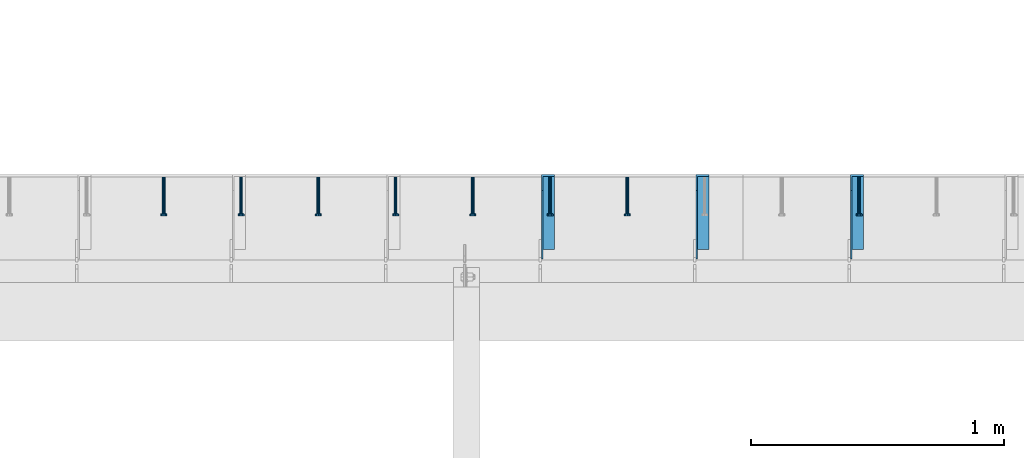
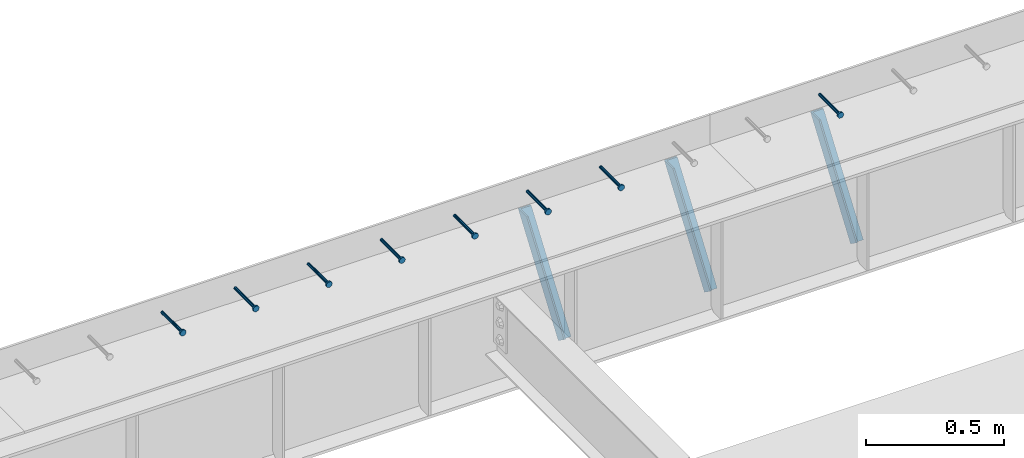
# One storey, part 1338 of 1763: 8 beams, 3 members, 9 elements without a shape of their own.
"""IFC2X3 building model written with IfcOpenShell, lengths in millimetres."""

from ifc_helpers import new_model, si_unit, frame, origin_with_axes, place, context, subcontext, project, spatial, faceted_brep, material, type_object, element, aggregate, save


model = new_model("IFC2X3")

# Units and contexts
model_context = context("Model", 3, precision=1e-05, world=origin_with_axes())
body_context = subcontext(model_context, "Body", "Model", "MODEL_VIEW")
ifc_project = project(units=[si_unit("LENGTHUNIT", "METRE", prefix="MILLI"), si_unit("AREAUNIT", "SQUARE_METRE"), si_unit("VOLUMEUNIT", "CUBIC_METRE"), si_unit("MASSUNIT", "GRAM", prefix="KILO"), si_unit("TIMEUNIT", "SECOND"), si_unit("PLANEANGLEUNIT", "RADIAN"), si_unit("SOLIDANGLEUNIT", "STERADIAN"), si_unit("THERMODYNAMICTEMPERATUREUNIT", "DEGREE_CELSIUS"), si_unit("LUMINOUSINTENSITYUNIT", "LUMEN")], contexts=[model_context])

# Site, building, storey
site_placement = place(None, origin_with_axes())
site = spatial("IfcSite", under=ifc_project, at=site_placement, CompositionType="ELEMENT")
building_placement = place(site_placement, origin_with_axes())
building = spatial("IfcBuilding", under=site, at=building_placement, Name="Undefined", CompositionType="ELEMENT")
storey_placement = place(building_placement, origin_with_axes())
storey = spatial("IfcBuildingStorey", under=building, at=storey_placement, Name="Undefined", CompositionType="ELEMENT", Elevation=0.0)

# Assembly, beam
assembly_1_placement = place(storey_placement, origin_with_axes())
assembly_1 = element("IfcElementAssembly", 1, at=assembly_1_placement, inside=storey, Name="HEADED STUD ANCHOR", AssemblyPlace="NOTDEFINED", PredefinedType="RIGID_FRAME")
ifc_material_1 = material(Name="STEEL/A108")
beam_type = type_object("IfcBeamType", PredefinedType="NOTDEFINED")
beam_1_placement = place(assembly_1_placement, frame((-78383.8372736983, 53984.5250183106, 5264.23140606069), z_axis=(0.0, 0.0, 1.0), x_axis=(0.0, -1.0, 0.0)))
beam_1 = element("IfcBeam", 2, at=beam_1_placement, type_object=beam_type, material=ifc_material_1, Name="HEADED STUD ANCHOR", context=body_context, shape_type="Brep", body=[
    faceted_brep([(0.0, -3.1800000667572, 5.5), (0.0, -5.5, 3.1800000667572), (141.732000000002, -5.5, 3.1800000667572), (141.732000000002, -3.1800000667572, 5.5), (0.0, -6.34999999999491, 1.45519152283669e-11), (141.732000000002, -6.34999990463257, 0.0), (0.0, -5.5, -3.1800000667572), (141.732000000002, -5.5, -3.1800000667572), (0.0, -3.1800000667572, -5.5), (141.732000000002, -3.1800000667572, -5.5), (0.0, 0.0, -6.34999990463257), (141.732000000002, 0.0, -6.34999990463257), (0.0, 3.1800000667572, -5.5), (141.732000000002, 3.1800000667572, -5.5), (0.0, 5.5, -3.1800000667572), (141.732000000002, 5.5, -3.1800000667572), (0.0, 6.34999999999491, -2.91038304567337e-11), (141.732000000002, 6.34999990463257, 0.0), (0.0, 5.5, 3.1800000667572), (141.732000000002, 5.5, 3.1800000667572), (0.0, 3.1800000667572, 5.5), (141.732000000002, 3.1800000667572, 5.5), (0.0, 0.0, 6.34999990463257), (141.732000000002, 0.0, 6.34999990463257), (144.780000000001, -10.9899997711182, 6.34999990463257), (144.780000000001, -6.34000015258789, 10.9899997711182), (144.780000000001, -12.6999998092651, 0.0), (144.780000000001, -10.9899997711182, -6.34999990463257), (144.780000000001, -6.34000015258789, -10.9899997711182), (144.780000000001, 0.0, -12.6899995803833), (144.780000000001, 6.34000015258789, -10.9899997711182), (144.780000000001, 10.9899997711182, -6.34999990463257), (144.780000000001, 12.6999998092651, 0.0), (144.780000000001, 10.9899997711182, 6.34999990463257), (144.780000000001, 6.34000015258789, 10.9899997711182), (144.780000000001, 0.0, 12.6899995803833), (152.400000000001, -10.9899997711182, 6.34999990463257), (152.400000000001, -6.34000015258789, 10.9899997711182), (152.400000000001, -12.6999998092651, 0.0), (152.400000000001, -10.9899997711182, -6.34999990463257), (152.400000000001, -6.34000015258789, -10.9899997711182), (152.400000000001, 0.0, -12.6899995803833), (152.400000000001, 6.34000015258789, -10.9899997711182), (152.400000000001, 10.9899997711182, -6.34999990463257), (152.400000000001, 12.6999998092651, 0.0), (152.400000000001, 10.9899997711182, 6.34999990463257), (152.400000000001, 6.34000015258789, 10.9899997711182), (152.400000000001, 0.0, 12.6899995803833)], [[[0, 1, 2, 3]], [[1, 4, 5, 2]], [[4, 6, 7, 5]], [[6, 8, 9, 7]], [[8, 10, 11, 9]], [[10, 12, 13, 11]], [[12, 14, 15, 13]], [[14, 16, 17, 15]], [[16, 18, 19, 17]], [[18, 20, 21, 19]], [[20, 22, 23, 21]], [[22, 0, 3, 23]], [[22, 20, 18, 16, 14, 12, 10, 8, 6, 4, 1, 0]], [[3, 2, 24, 25]], [[2, 5, 26, 24]], [[5, 7, 27, 26]], [[7, 9, 28, 27]], [[9, 11, 29, 28]], [[11, 13, 30, 29]], [[13, 15, 31, 30]], [[15, 17, 32, 31]], [[17, 19, 33, 32]], [[19, 21, 34, 33]], [[21, 23, 35, 34]], [[23, 3, 25, 35]], [[25, 24, 36, 37]], [[24, 26, 38, 36]], [[26, 27, 39, 38]], [[27, 28, 40, 39]], [[28, 29, 41, 40]], [[29, 30, 42, 41]], [[30, 31, 43, 42]], [[31, 32, 44, 43]], [[32, 33, 45, 44]], [[33, 34, 46, 45]], [[34, 35, 47, 46]], [[35, 25, 37, 47]], [[38, 39, 40, 41, 42, 43, 44, 45, 46, 47, 37, 36]]]),
])
aggregate(assembly_1, [beam_1])

assembly_2_placement = place(storey_placement, origin_with_axes())
assembly_2 = element("IfcElementAssembly", 3, at=assembly_2_placement, inside=storey, Name="HEADED STUD ANCHOR", AssemblyPlace="NOTDEFINED", PredefinedType="RIGID_FRAME")
beam_2_placement = place(assembly_2_placement, frame((-79298.2372736984, 53984.5250183106, 5264.23140606069), z_axis=(0.0, 0.0, 1.0), x_axis=(0.0, -1.0, 0.0)))
beam_2 = element("IfcBeam", 4, at=beam_2_placement, type_object=beam_type, material=ifc_material_1, Name="HEADED STUD ANCHOR", context=body_context, shape_type="Brep", body=[
    faceted_brep([(0.0, -3.1800000667572, 5.5), (0.0, -5.5, 3.1800000667572), (141.732000000002, -5.5, 3.1800000667572), (141.732000000002, -3.1800000667572, 5.5), (0.0, -6.34999999999491, 1.45519152283669e-11), (141.732000000002, -6.34999990463257, 0.0), (0.0, -5.5, -3.1800000667572), (141.732000000002, -5.5, -3.1800000667572), (0.0, -3.1800000667572, -5.5), (141.732000000002, -3.1800000667572, -5.5), (0.0, 0.0, -6.34999990463257), (141.732000000002, 0.0, -6.34999990463257), (0.0, 3.1800000667572, -5.5), (141.732000000002, 3.1800000667572, -5.5), (0.0, 5.5, -3.1800000667572), (141.732000000002, 5.5, -3.1800000667572), (0.0, 6.34999999999491, -2.91038304567337e-11), (141.732000000002, 6.34999990463257, 0.0), (0.0, 5.5, 3.1800000667572), (141.732000000002, 5.5, 3.1800000667572), (0.0, 3.1800000667572, 5.5), (141.732000000002, 3.1800000667572, 5.5), (0.0, 0.0, 6.34999990463257), (141.732000000002, 0.0, 6.34999990463257), (144.780000000001, -10.9899997711182, 6.34999990463257), (144.780000000001, -6.34000015258789, 10.9899997711182), (144.780000000001, -12.6999998092651, 0.0), (144.780000000001, -10.9899997711182, -6.34999990463257), (144.780000000001, -6.34000015258789, -10.9899997711182), (144.780000000001, 0.0, -12.6899995803833), (144.780000000001, 6.34000015258789, -10.9899997711182), (144.780000000001, 10.9899997711182, -6.34999990463257), (144.780000000001, 12.6999998092651, 0.0), (144.780000000001, 10.9899997711182, 6.34999990463257), (144.780000000001, 6.34000015258789, 10.9899997711182), (144.780000000001, 0.0, 12.6899995803833), (152.400000000001, -10.9899997711182, 6.34999990463257), (152.400000000001, -6.34000015258789, 10.9899997711182), (152.400000000001, -12.6999998092651, 0.0), (152.400000000001, -10.9899997711182, -6.34999990463257), (152.400000000001, -6.34000015258789, -10.9899997711182), (152.400000000001, 0.0, -12.6899995803833), (152.400000000001, 6.34000015258789, -10.9899997711182), (152.400000000001, 10.9899997711182, -6.34999990463257), (152.400000000001, 12.6999998092651, 0.0), (152.400000000001, 10.9899997711182, 6.34999990463257), (152.400000000001, 6.34000015258789, 10.9899997711182), (152.400000000001, 0.0, 12.6899995803833)], [[[0, 1, 2, 3]], [[1, 4, 5, 2]], [[4, 6, 7, 5]], [[6, 8, 9, 7]], [[8, 10, 11, 9]], [[10, 12, 13, 11]], [[12, 14, 15, 13]], [[14, 16, 17, 15]], [[16, 18, 19, 17]], [[18, 20, 21, 19]], [[20, 22, 23, 21]], [[22, 0, 3, 23]], [[22, 20, 18, 16, 14, 12, 10, 8, 6, 4, 1, 0]], [[3, 2, 24, 25]], [[2, 5, 26, 24]], [[5, 7, 27, 26]], [[7, 9, 28, 27]], [[9, 11, 29, 28]], [[11, 13, 30, 29]], [[13, 15, 31, 30]], [[15, 17, 32, 31]], [[17, 19, 33, 32]], [[19, 21, 34, 33]], [[21, 23, 35, 34]], [[23, 3, 25, 35]], [[25, 24, 36, 37]], [[24, 26, 38, 36]], [[26, 27, 39, 38]], [[27, 28, 40, 39]], [[28, 29, 41, 40]], [[29, 30, 42, 41]], [[30, 31, 43, 42]], [[31, 32, 44, 43]], [[32, 33, 45, 44]], [[33, 34, 46, 45]], [[34, 35, 47, 46]], [[35, 25, 37, 47]], [[38, 39, 40, 41, 42, 43, 44, 45, 46, 47, 37, 36]]]),
])
aggregate(assembly_2, [beam_2])

assembly_3_placement = place(storey_placement, origin_with_axes())
assembly_3 = element("IfcElementAssembly", 5, at=assembly_3_placement, inside=storey, Name="HEADED STUD ANCHOR", AssemblyPlace="NOTDEFINED", PredefinedType="RIGID_FRAME")
beam_3_placement = place(assembly_3_placement, frame((-79603.0372736983, 53984.5250183106, 5264.23140606069), z_axis=(0.0, 0.0, 1.0), x_axis=(0.0, -1.0, 0.0)))
beam_3 = element("IfcBeam", 6, at=beam_3_placement, type_object=beam_type, material=ifc_material_1, Name="HEADED STUD ANCHOR", context=body_context, shape_type="Brep", body=[
    faceted_brep([(0.0, -3.1800000667572, 5.5), (0.0, -5.5, 3.1800000667572), (141.732000000002, -5.5, 3.1800000667572), (141.732000000002, -3.1800000667572, 5.5), (0.0, -6.34999999999491, 1.45519152283669e-11), (141.732000000002, -6.34999990463257, 0.0), (0.0, -5.5, -3.1800000667572), (141.732000000002, -5.5, -3.1800000667572), (0.0, -3.1800000667572, -5.5), (141.732000000002, -3.1800000667572, -5.5), (0.0, 0.0, -6.34999990463257), (141.732000000002, 0.0, -6.34999990463257), (0.0, 3.1800000667572, -5.5), (141.732000000002, 3.1800000667572, -5.5), (0.0, 5.5, -3.1800000667572), (141.732000000002, 5.5, -3.1800000667572), (0.0, 6.34999999999491, -2.91038304567337e-11), (141.732000000002, 6.34999990463257, 0.0), (0.0, 5.5, 3.1800000667572), (141.732000000002, 5.5, 3.1800000667572), (0.0, 3.1800000667572, 5.5), (141.732000000002, 3.1800000667572, 5.5), (0.0, 0.0, 6.34999990463257), (141.732000000002, 0.0, 6.34999990463257), (144.780000000001, -10.9899997711182, 6.34999990463257), (144.780000000001, -6.34000015258789, 10.9899997711182), (144.780000000001, -12.6999998092651, 0.0), (144.780000000001, -10.9899997711182, -6.34999990463257), (144.780000000001, -6.34000015258789, -10.9899997711182), (144.780000000001, 0.0, -12.6899995803833), (144.780000000001, 6.34000015258789, -10.9899997711182), (144.780000000001, 10.9899997711182, -6.34999990463257), (144.780000000001, 12.6999998092651, 0.0), (144.780000000001, 10.9899997711182, 6.34999990463257), (144.780000000001, 6.34000015258789, 10.9899997711182), (144.780000000001, 0.0, 12.6899995803833), (152.400000000001, -10.9899997711182, 6.34999990463257), (152.400000000001, -6.34000015258789, 10.9899997711182), (152.400000000001, -12.6999998092651, 0.0), (152.400000000001, -10.9899997711182, -6.34999990463257), (152.400000000001, -6.34000015258789, -10.9899997711182), (152.400000000001, 0.0, -12.6899995803833), (152.400000000001, 6.34000015258789, -10.9899997711182), (152.400000000001, 10.9899997711182, -6.34999990463257), (152.400000000001, 12.6999998092651, 0.0), (152.400000000001, 10.9899997711182, 6.34999990463257), (152.400000000001, 6.34000015258789, 10.9899997711182), (152.400000000001, 0.0, 12.6899995803833)], [[[0, 1, 2, 3]], [[1, 4, 5, 2]], [[4, 6, 7, 5]], [[6, 8, 9, 7]], [[8, 10, 11, 9]], [[10, 12, 13, 11]], [[12, 14, 15, 13]], [[14, 16, 17, 15]], [[16, 18, 19, 17]], [[18, 20, 21, 19]], [[20, 22, 23, 21]], [[22, 0, 3, 23]], [[22, 20, 18, 16, 14, 12, 10, 8, 6, 4, 1, 0]], [[3, 2, 24, 25]], [[2, 5, 26, 24]], [[5, 7, 27, 26]], [[7, 9, 28, 27]], [[9, 11, 29, 28]], [[11, 13, 30, 29]], [[13, 15, 31, 30]], [[15, 17, 32, 31]], [[17, 19, 33, 32]], [[19, 21, 34, 33]], [[21, 23, 35, 34]], [[23, 3, 25, 35]], [[25, 24, 36, 37]], [[24, 26, 38, 36]], [[26, 27, 39, 38]], [[27, 28, 40, 39]], [[28, 29, 41, 40]], [[29, 30, 42, 41]], [[30, 31, 43, 42]], [[31, 32, 44, 43]], [[32, 33, 45, 44]], [[33, 34, 46, 45]], [[34, 35, 47, 46]], [[35, 25, 37, 47]], [[38, 39, 40, 41, 42, 43, 44, 45, 46, 47, 37, 36]]]),
])
aggregate(assembly_3, [beam_3])

assembly_4_placement = place(storey_placement, origin_with_axes())
assembly_4 = element("IfcElementAssembly", 7, at=assembly_4_placement, inside=storey, Name="HEADED STUD ANCHOR", AssemblyPlace="NOTDEFINED", PredefinedType="RIGID_FRAME")
beam_4_placement = place(assembly_4_placement, frame((-79907.8372736983, 53984.5250183106, 5264.23140606069), z_axis=(0.0, 0.0, 1.0), x_axis=(0.0, -1.0, 0.0)))
beam_4 = element("IfcBeam", 8, at=beam_4_placement, type_object=beam_type, material=ifc_material_1, Name="HEADED STUD ANCHOR", context=body_context, shape_type="Brep", body=[
    faceted_brep([(0.0, -3.1800000667572, 5.5), (0.0, -5.5, 3.1800000667572), (141.732000000002, -5.5, 3.1800000667572), (141.732000000002, -3.1800000667572, 5.5), (0.0, -6.34999999999491, 1.45519152283669e-11), (141.732000000002, -6.34999990463257, 0.0), (0.0, -5.5, -3.1800000667572), (141.732000000002, -5.5, -3.1800000667572), (0.0, -3.1800000667572, -5.5), (141.732000000002, -3.1800000667572, -5.5), (0.0, 0.0, -6.34999990463257), (141.732000000002, 0.0, -6.34999990463257), (0.0, 3.1800000667572, -5.5), (141.732000000002, 3.1800000667572, -5.5), (0.0, 5.5, -3.1800000667572), (141.732000000002, 5.5, -3.1800000667572), (0.0, 6.34999999999491, -2.91038304567337e-11), (141.732000000002, 6.34999990463257, 0.0), (0.0, 5.5, 3.1800000667572), (141.732000000002, 5.5, 3.1800000667572), (0.0, 3.1800000667572, 5.5), (141.732000000002, 3.1800000667572, 5.5), (0.0, 0.0, 6.34999990463257), (141.732000000002, 0.0, 6.34999990463257), (144.780000000001, -10.9899997711182, 6.34999990463257), (144.780000000001, -6.34000015258789, 10.9899997711182), (144.780000000001, -12.6999998092651, 0.0), (144.780000000001, -10.9899997711182, -6.34999990463257), (144.780000000001, -6.34000015258789, -10.9899997711182), (144.780000000001, 0.0, -12.6899995803833), (144.780000000001, 6.34000015258789, -10.9899997711182), (144.780000000001, 10.9899997711182, -6.34999990463257), (144.780000000001, 12.6999998092651, 0.0), (144.780000000001, 10.9899997711182, 6.34999990463257), (144.780000000001, 6.34000015258789, 10.9899997711182), (144.780000000001, 0.0, 12.6899995803833), (152.400000000001, -10.9899997711182, 6.34999990463257), (152.400000000001, -6.34000015258789, 10.9899997711182), (152.400000000001, -12.6999998092651, 0.0), (152.400000000001, -10.9899997711182, -6.34999990463257), (152.400000000001, -6.34000015258789, -10.9899997711182), (152.400000000001, 0.0, -12.6899995803833), (152.400000000001, 6.34000015258789, -10.9899997711182), (152.400000000001, 10.9899997711182, -6.34999990463257), (152.400000000001, 12.6999998092651, 0.0), (152.400000000001, 10.9899997711182, 6.34999990463257), (152.400000000001, 6.34000015258789, 10.9899997711182), (152.400000000001, 0.0, 12.6899995803833)], [[[0, 1, 2, 3]], [[1, 4, 5, 2]], [[4, 6, 7, 5]], [[6, 8, 9, 7]], [[8, 10, 11, 9]], [[10, 12, 13, 11]], [[12, 14, 15, 13]], [[14, 16, 17, 15]], [[16, 18, 19, 17]], [[18, 20, 21, 19]], [[20, 22, 23, 21]], [[22, 0, 3, 23]], [[22, 20, 18, 16, 14, 12, 10, 8, 6, 4, 1, 0]], [[3, 2, 24, 25]], [[2, 5, 26, 24]], [[5, 7, 27, 26]], [[7, 9, 28, 27]], [[9, 11, 29, 28]], [[11, 13, 30, 29]], [[13, 15, 31, 30]], [[15, 17, 32, 31]], [[17, 19, 33, 32]], [[19, 21, 34, 33]], [[21, 23, 35, 34]], [[23, 3, 25, 35]], [[25, 24, 36, 37]], [[24, 26, 38, 36]], [[26, 27, 39, 38]], [[27, 28, 40, 39]], [[28, 29, 41, 40]], [[29, 30, 42, 41]], [[30, 31, 43, 42]], [[31, 32, 44, 43]], [[32, 33, 45, 44]], [[33, 34, 46, 45]], [[34, 35, 47, 46]], [[35, 25, 37, 47]], [[38, 39, 40, 41, 42, 43, 44, 45, 46, 47, 37, 36]]]),
])
aggregate(assembly_4, [beam_4])

assembly_5_placement = place(storey_placement, origin_with_axes())
assembly_5 = element("IfcElementAssembly", 9, at=assembly_5_placement, inside=storey, Name="HEADED STUD ANCHOR", AssemblyPlace="NOTDEFINED", PredefinedType="RIGID_FRAME")
beam_5_placement = place(assembly_5_placement, frame((-80212.6372736983, 53984.5250183106, 5264.23140606069), z_axis=(0.0, 0.0, 1.0), x_axis=(0.0, -1.0, 0.0)))
beam_5 = element("IfcBeam", 10, at=beam_5_placement, type_object=beam_type, material=ifc_material_1, Name="HEADED STUD ANCHOR", context=body_context, shape_type="Brep", body=[
    faceted_brep([(0.0, -3.1800000667572, 5.5), (0.0, -5.5, 3.1800000667572), (141.732000000002, -5.5, 3.1800000667572), (141.732000000002, -3.1800000667572, 5.5), (0.0, -6.34999999999491, 1.45519152283669e-11), (141.732000000002, -6.34999990463257, 0.0), (0.0, -5.5, -3.1800000667572), (141.732000000002, -5.5, -3.1800000667572), (0.0, -3.1800000667572, -5.5), (141.732000000002, -3.1800000667572, -5.5), (0.0, 0.0, -6.34999990463257), (141.732000000002, 0.0, -6.34999990463257), (0.0, 3.1800000667572, -5.5), (141.732000000002, 3.1800000667572, -5.5), (0.0, 5.5, -3.1800000667572), (141.732000000002, 5.5, -3.1800000667572), (0.0, 6.34999999999491, -2.91038304567337e-11), (141.732000000002, 6.34999990463257, 0.0), (0.0, 5.5, 3.1800000667572), (141.732000000002, 5.5, 3.1800000667572), (0.0, 3.1800000667572, 5.5), (141.732000000002, 3.1800000667572, 5.5), (0.0, 0.0, 6.34999990463257), (141.732000000002, 0.0, 6.34999990463257), (144.780000000001, -10.9899997711182, 6.34999990463257), (144.780000000001, -6.34000015258789, 10.9899997711182), (144.780000000001, -12.6999998092651, 0.0), (144.780000000001, -10.9899997711182, -6.34999990463257), (144.780000000001, -6.34000015258789, -10.9899997711182), (144.780000000001, 0.0, -12.6899995803833), (144.780000000001, 6.34000015258789, -10.9899997711182), (144.780000000001, 10.9899997711182, -6.34999990463257), (144.780000000001, 12.6999998092651, 0.0), (144.780000000001, 10.9899997711182, 6.34999990463257), (144.780000000001, 6.34000015258789, 10.9899997711182), (144.780000000001, 0.0, 12.6899995803833), (152.400000000001, -10.9899997711182, 6.34999990463257), (152.400000000001, -6.34000015258789, 10.9899997711182), (152.400000000001, -12.6999998092651, 0.0), (152.400000000001, -10.9899997711182, -6.34999990463257), (152.400000000001, -6.34000015258789, -10.9899997711182), (152.400000000001, 0.0, -12.6899995803833), (152.400000000001, 6.34000015258789, -10.9899997711182), (152.400000000001, 10.9899997711182, -6.34999990463257), (152.400000000001, 12.6999998092651, 0.0), (152.400000000001, 10.9899997711182, 6.34999990463257), (152.400000000001, 6.34000015258789, 10.9899997711182), (152.400000000001, 0.0, 12.6899995803833)], [[[0, 1, 2, 3]], [[1, 4, 5, 2]], [[4, 6, 7, 5]], [[6, 8, 9, 7]], [[8, 10, 11, 9]], [[10, 12, 13, 11]], [[12, 14, 15, 13]], [[14, 16, 17, 15]], [[16, 18, 19, 17]], [[18, 20, 21, 19]], [[20, 22, 23, 21]], [[22, 0, 3, 23]], [[22, 20, 18, 16, 14, 12, 10, 8, 6, 4, 1, 0]], [[3, 2, 24, 25]], [[2, 5, 26, 24]], [[5, 7, 27, 26]], [[7, 9, 28, 27]], [[9, 11, 29, 28]], [[11, 13, 30, 29]], [[13, 15, 31, 30]], [[15, 17, 32, 31]], [[17, 19, 33, 32]], [[19, 21, 34, 33]], [[21, 23, 35, 34]], [[23, 3, 25, 35]], [[25, 24, 36, 37]], [[24, 26, 38, 36]], [[26, 27, 39, 38]], [[27, 28, 40, 39]], [[28, 29, 41, 40]], [[29, 30, 42, 41]], [[30, 31, 43, 42]], [[31, 32, 44, 43]], [[32, 33, 45, 44]], [[33, 34, 46, 45]], [[34, 35, 47, 46]], [[35, 25, 37, 47]], [[38, 39, 40, 41, 42, 43, 44, 45, 46, 47, 37, 36]]]),
])
aggregate(assembly_5, [beam_5])

assembly_6_placement = place(storey_placement, origin_with_axes())
assembly_6 = element("IfcElementAssembly", 11, at=assembly_6_placement, inside=storey, Name="HEADED STUD ANCHOR", AssemblyPlace="NOTDEFINED", PredefinedType="RIGID_FRAME")
beam_6_placement = place(assembly_6_placement, frame((-80517.4372736983, 53984.5250183106, 5264.23140606069), z_axis=(0.0, 0.0, 1.0), x_axis=(0.0, -1.0, 0.0)))
beam_6 = element("IfcBeam", 12, at=beam_6_placement, type_object=beam_type, material=ifc_material_1, Name="HEADED STUD ANCHOR", context=body_context, shape_type="Brep", body=[
    faceted_brep([(0.0, -3.1800000667572, 5.5), (0.0, -5.5, 3.1800000667572), (141.732000000002, -5.5, 3.1800000667572), (141.732000000002, -3.1800000667572, 5.5), (0.0, -6.34999999999491, 1.45519152283669e-11), (141.732000000002, -6.34999990463257, 0.0), (0.0, -5.5, -3.1800000667572), (141.732000000002, -5.5, -3.1800000667572), (0.0, -3.1800000667572, -5.5), (141.732000000002, -3.1800000667572, -5.5), (0.0, 0.0, -6.34999990463257), (141.732000000002, 0.0, -6.34999990463257), (0.0, 3.1800000667572, -5.5), (141.732000000002, 3.1800000667572, -5.5), (0.0, 5.5, -3.1800000667572), (141.732000000002, 5.5, -3.1800000667572), (0.0, 6.34999999999491, -2.91038304567337e-11), (141.732000000002, 6.34999990463257, 0.0), (0.0, 5.5, 3.1800000667572), (141.732000000002, 5.5, 3.1800000667572), (0.0, 3.1800000667572, 5.5), (141.732000000002, 3.1800000667572, 5.5), (0.0, 0.0, 6.34999990463257), (141.732000000002, 0.0, 6.34999990463257), (144.780000000001, -10.9899997711182, 6.34999990463257), (144.780000000001, -6.34000015258789, 10.9899997711182), (144.780000000001, -12.6999998092651, 0.0), (144.780000000001, -10.9899997711182, -6.34999990463257), (144.780000000001, -6.34000015258789, -10.9899997711182), (144.780000000001, 0.0, -12.6899995803833), (144.780000000001, 6.34000015258789, -10.9899997711182), (144.780000000001, 10.9899997711182, -6.34999990463257), (144.780000000001, 12.6999998092651, 0.0), (144.780000000001, 10.9899997711182, 6.34999990463257), (144.780000000001, 6.34000015258789, 10.9899997711182), (144.780000000001, 0.0, 12.6899995803833), (152.400000000001, -10.9899997711182, 6.34999990463257), (152.400000000001, -6.34000015258789, 10.9899997711182), (152.400000000001, -12.6999998092651, 0.0), (152.400000000001, -10.9899997711182, -6.34999990463257), (152.400000000001, -6.34000015258789, -10.9899997711182), (152.400000000001, 0.0, -12.6899995803833), (152.400000000001, 6.34000015258789, -10.9899997711182), (152.400000000001, 10.9899997711182, -6.34999990463257), (152.400000000001, 12.6999998092651, 0.0), (152.400000000001, 10.9899997711182, 6.34999990463257), (152.400000000001, 6.34000015258789, 10.9899997711182), (152.400000000001, 0.0, 12.6899995803833)], [[[0, 1, 2, 3]], [[1, 4, 5, 2]], [[4, 6, 7, 5]], [[6, 8, 9, 7]], [[8, 10, 11, 9]], [[10, 12, 13, 11]], [[12, 14, 15, 13]], [[14, 16, 17, 15]], [[16, 18, 19, 17]], [[18, 20, 21, 19]], [[20, 22, 23, 21]], [[22, 0, 3, 23]], [[22, 20, 18, 16, 14, 12, 10, 8, 6, 4, 1, 0]], [[3, 2, 24, 25]], [[2, 5, 26, 24]], [[5, 7, 27, 26]], [[7, 9, 28, 27]], [[9, 11, 29, 28]], [[11, 13, 30, 29]], [[13, 15, 31, 30]], [[15, 17, 32, 31]], [[17, 19, 33, 32]], [[19, 21, 34, 33]], [[21, 23, 35, 34]], [[23, 3, 25, 35]], [[25, 24, 36, 37]], [[24, 26, 38, 36]], [[26, 27, 39, 38]], [[27, 28, 40, 39]], [[28, 29, 41, 40]], [[29, 30, 42, 41]], [[30, 31, 43, 42]], [[31, 32, 44, 43]], [[32, 33, 45, 44]], [[33, 34, 46, 45]], [[34, 35, 47, 46]], [[35, 25, 37, 47]], [[38, 39, 40, 41, 42, 43, 44, 45, 46, 47, 37, 36]]]),
])
aggregate(assembly_6, [beam_6])

assembly_7_placement = place(storey_placement, origin_with_axes())
assembly_7 = element("IfcElementAssembly", 13, at=assembly_7_placement, inside=storey, Name="HEADED STUD ANCHOR", AssemblyPlace="NOTDEFINED", PredefinedType="RIGID_FRAME")
beam_7_placement = place(assembly_7_placement, frame((-80822.2372736984, 53984.5250183106, 5264.23140606069), z_axis=(0.0, 0.0, 1.0), x_axis=(0.0, -1.0, 0.0)))
beam_7 = element("IfcBeam", 14, at=beam_7_placement, type_object=beam_type, material=ifc_material_1, Name="HEADED STUD ANCHOR", context=body_context, shape_type="Brep", body=[
    faceted_brep([(0.0, -3.1800000667572, 5.5), (0.0, -5.5, 3.1800000667572), (141.732000000002, -5.5, 3.1800000667572), (141.732000000002, -3.1800000667572, 5.5), (0.0, -6.34999999999491, 1.45519152283669e-11), (141.732000000002, -6.34999990463257, 0.0), (0.0, -5.5, -3.1800000667572), (141.732000000002, -5.5, -3.1800000667572), (0.0, -3.1800000667572, -5.5), (141.732000000002, -3.1800000667572, -5.5), (0.0, 0.0, -6.34999990463257), (141.732000000002, 0.0, -6.34999990463257), (0.0, 3.1800000667572, -5.5), (141.732000000002, 3.1800000667572, -5.5), (0.0, 5.5, -3.1800000667572), (141.732000000002, 5.5, -3.1800000667572), (0.0, 6.34999999999491, -2.91038304567337e-11), (141.732000000002, 6.34999990463257, 0.0), (0.0, 5.5, 3.1800000667572), (141.732000000002, 5.5, 3.1800000667572), (0.0, 3.1800000667572, 5.5), (141.732000000002, 3.1800000667572, 5.5), (0.0, 0.0, 6.34999990463257), (141.732000000002, 0.0, 6.34999990463257), (144.780000000001, -10.9899997711182, 6.34999990463257), (144.780000000001, -6.34000015258789, 10.9899997711182), (144.780000000001, -12.6999998092651, 0.0), (144.780000000001, -10.9899997711182, -6.34999990463257), (144.780000000001, -6.34000015258789, -10.9899997711182), (144.780000000001, 0.0, -12.6899995803833), (144.780000000001, 6.34000015258789, -10.9899997711182), (144.780000000001, 10.9899997711182, -6.34999990463257), (144.780000000001, 12.6999998092651, 0.0), (144.780000000001, 10.9899997711182, 6.34999990463257), (144.780000000001, 6.34000015258789, 10.9899997711182), (144.780000000001, 0.0, 12.6899995803833), (152.400000000001, -10.9899997711182, 6.34999990463257), (152.400000000001, -6.34000015258789, 10.9899997711182), (152.400000000001, -12.6999998092651, 0.0), (152.400000000001, -10.9899997711182, -6.34999990463257), (152.400000000001, -6.34000015258789, -10.9899997711182), (152.400000000001, 0.0, -12.6899995803833), (152.400000000001, 6.34000015258789, -10.9899997711182), (152.400000000001, 10.9899997711182, -6.34999990463257), (152.400000000001, 12.6999998092651, 0.0), (152.400000000001, 10.9899997711182, 6.34999990463257), (152.400000000001, 6.34000015258789, 10.9899997711182), (152.400000000001, 0.0, 12.6899995803833)], [[[0, 1, 2, 3]], [[1, 4, 5, 2]], [[4, 6, 7, 5]], [[6, 8, 9, 7]], [[8, 10, 11, 9]], [[10, 12, 13, 11]], [[12, 14, 15, 13]], [[14, 16, 17, 15]], [[16, 18, 19, 17]], [[18, 20, 21, 19]], [[20, 22, 23, 21]], [[22, 0, 3, 23]], [[22, 20, 18, 16, 14, 12, 10, 8, 6, 4, 1, 0]], [[3, 2, 24, 25]], [[2, 5, 26, 24]], [[5, 7, 27, 26]], [[7, 9, 28, 27]], [[9, 11, 29, 28]], [[11, 13, 30, 29]], [[13, 15, 31, 30]], [[15, 17, 32, 31]], [[17, 19, 33, 32]], [[19, 21, 34, 33]], [[21, 23, 35, 34]], [[23, 3, 25, 35]], [[25, 24, 36, 37]], [[24, 26, 38, 36]], [[26, 27, 39, 38]], [[27, 28, 40, 39]], [[28, 29, 41, 40]], [[29, 30, 42, 41]], [[30, 31, 43, 42]], [[31, 32, 44, 43]], [[32, 33, 45, 44]], [[33, 34, 46, 45]], [[34, 35, 47, 46]], [[35, 25, 37, 47]], [[38, 39, 40, 41, 42, 43, 44, 45, 46, 47, 37, 36]]]),
])
aggregate(assembly_7, [beam_7])

assembly_8_placement = place(storey_placement, origin_with_axes())
assembly_8 = element("IfcElementAssembly", 15, at=assembly_8_placement, inside=storey, Name="HEADED STUD ANCHOR", AssemblyPlace="NOTDEFINED", PredefinedType="RIGID_FRAME")
beam_8_placement = place(assembly_8_placement, frame((-81127.0372736983, 53984.5250183106, 5264.23140606069), z_axis=(0.0, 0.0, 1.0), x_axis=(0.0, -1.0, 0.0)))
beam_8 = element("IfcBeam", 16, at=beam_8_placement, type_object=beam_type, material=ifc_material_1, Name="HEADED STUD ANCHOR", context=body_context, shape_type="Brep", body=[
    faceted_brep([(0.0, -3.1800000667572, 5.5), (0.0, -5.5, 3.1800000667572), (141.732000000002, -5.5, 3.1800000667572), (141.732000000002, -3.1800000667572, 5.5), (0.0, -6.34999999999491, 1.45519152283669e-11), (141.732000000002, -6.34999990463257, 0.0), (0.0, -5.5, -3.1800000667572), (141.732000000002, -5.5, -3.1800000667572), (0.0, -3.1800000667572, -5.5), (141.732000000002, -3.1800000667572, -5.5), (0.0, 0.0, -6.34999990463257), (141.732000000002, 0.0, -6.34999990463257), (0.0, 3.1800000667572, -5.5), (141.732000000002, 3.1800000667572, -5.5), (0.0, 5.5, -3.1800000667572), (141.732000000002, 5.5, -3.1800000667572), (0.0, 6.34999999999491, -2.91038304567337e-11), (141.732000000002, 6.34999990463257, 0.0), (0.0, 5.5, 3.1800000667572), (141.732000000002, 5.5, 3.1800000667572), (0.0, 3.1800000667572, 5.5), (141.732000000002, 3.1800000667572, 5.5), (0.0, 0.0, 6.34999990463257), (141.732000000002, 0.0, 6.34999990463257), (144.780000000001, -10.9899997711182, 6.34999990463257), (144.780000000001, -6.34000015258789, 10.9899997711182), (144.780000000001, -12.6999998092651, 0.0), (144.780000000001, -10.9899997711182, -6.34999990463257), (144.780000000001, -6.34000015258789, -10.9899997711182), (144.780000000001, 0.0, -12.6899995803833), (144.780000000001, 6.34000015258789, -10.9899997711182), (144.780000000001, 10.9899997711182, -6.34999990463257), (144.780000000001, 12.6999998092651, 0.0), (144.780000000001, 10.9899997711182, 6.34999990463257), (144.780000000001, 6.34000015258789, 10.9899997711182), (144.780000000001, 0.0, 12.6899995803833), (152.400000000001, -10.9899997711182, 6.34999990463257), (152.400000000001, -6.34000015258789, 10.9899997711182), (152.400000000001, -12.6999998092651, 0.0), (152.400000000001, -10.9899997711182, -6.34999990463257), (152.400000000001, -6.34000015258789, -10.9899997711182), (152.400000000001, 0.0, -12.6899995803833), (152.400000000001, 6.34000015258789, -10.9899997711182), (152.400000000001, 10.9899997711182, -6.34999990463257), (152.400000000001, 12.6999998092651, 0.0), (152.400000000001, 10.9899997711182, 6.34999990463257), (152.400000000001, 6.34000015258789, 10.9899997711182), (152.400000000001, 0.0, 12.6899995803833)], [[[0, 1, 2, 3]], [[1, 4, 5, 2]], [[4, 6, 7, 5]], [[6, 8, 9, 7]], [[8, 10, 11, 9]], [[10, 12, 13, 11]], [[12, 14, 15, 13]], [[14, 16, 17, 15]], [[16, 18, 19, 17]], [[18, 20, 21, 19]], [[20, 22, 23, 21]], [[22, 0, 3, 23]], [[22, 20, 18, 16, 14, 12, 10, 8, 6, 4, 1, 0]], [[3, 2, 24, 25]], [[2, 5, 26, 24]], [[5, 7, 27, 26]], [[7, 9, 28, 27]], [[9, 11, 29, 28]], [[11, 13, 30, 29]], [[13, 15, 31, 30]], [[15, 17, 32, 31]], [[17, 19, 33, 32]], [[19, 21, 34, 33]], [[21, 23, 35, 34]], [[23, 3, 25, 35]], [[25, 24, 36, 37]], [[24, 26, 38, 36]], [[26, 27, 39, 38]], [[27, 28, 40, 39]], [[28, 29, 41, 40]], [[29, 30, 42, 41]], [[30, 31, 43, 42]], [[31, 32, 44, 43]], [[32, 33, 45, 44]], [[33, 34, 46, 45]], [[34, 35, 47, 46]], [[35, 25, 37, 47]], [[38, 39, 40, 41, 42, 43, 44, 45, 46, 47, 37, 36]]]),
])
aggregate(assembly_8, [beam_8])

# Assembly, members
assembly_9_placement = place(storey_placement, origin_with_axes())
assembly_9 = element("IfcElementAssembly", 17, at=assembly_9_placement, inside=storey, Name="BEAM", AssemblyPlace="NOTDEFINED", PredefinedType="RIGID_FRAME")
ifc_material_2 = material(Name="STEEL/A36")
member_type = type_object("IfcMemberType", Name="L2X2X1/4", PredefinedType="NOTDEFINED")
member_1_placement = place(assembly_9_placement, frame((-78392.1716486984, 53682.7083833994, 4801.55161052494), z_axis=(0.0, -0.814117947745209, 0.580699549818259), x_axis=(0.0, 0.58069954981826, 0.814117947745209)))
member_1 = element("IfcMember", 18, at=member_1_placement, type_object=member_type, material=ifc_material_2, Name="ANGLE", ObjectType="L2X2X1/4", context=body_context, shape_type="Brep", body=[
    faceted_brep([(-1.45519152283669e-11, 25.4000000000015, -25.3999999999869), (1.45519152283669e-11, 25.4000000000015, 25.3999999999796), (464.304493432646, 25.4000000000015, 25.3999999991429), (500.539460322936, 25.4000000000015, -25.4000000009546), (1.45519152283669e-11, 19.0499999999993, 25.3999999999796), (464.304493432646, 19.0500000000029, 25.3999999991429), (-7.27595761418343e-12, 19.0499999999993, -19.0499999999956), (496.010089461648, 19.0500000000029, -19.0500000009415), (-7.27595761418343e-12, -25.4000000000015, -19.0499999999956), (496.010089461648, -25.4000000000015, -19.0500000009415), (-1.45519152283669e-11, -25.4000000000015, -25.3999999999869), (500.539460322936, -25.4000000000015, -25.4000000009546)], [[[0, 1, 2, 3]], [[1, 4, 5, 2]], [[4, 6, 7, 5]], [[6, 8, 9, 7]], [[8, 10, 11, 9]], [[10, 0, 3, 11]], [[5, 7, 9, 11, 3, 2]], [[10, 8, 6, 4, 1, 0]]]),
])
member_2_placement = place(assembly_9_placement, frame((-79611.3716486984, 53682.7083833994, 4801.55161052494), z_axis=(0.0, -0.814117947745209, 0.580699549818259), x_axis=(0.0, 0.58069954981826, 0.814117947745209)))
member_2 = element("IfcMember", 19, at=member_2_placement, type_object=member_type, material=ifc_material_2, Name="ANGLE", ObjectType="L2X2X1/4", context=body_context, shape_type="Brep", body=[
    faceted_brep([(-1.45519152283669e-11, 25.4000000000015, -25.3999999999869), (1.45519152283669e-11, 25.4000000000015, 25.3999999999796), (464.304493432646, 25.4000000000015, 25.3999999991429), (500.539460322936, 25.4000000000015, -25.4000000009546), (1.45519152283669e-11, 19.0499999999993, 25.3999999999796), (464.304493432646, 19.0500000000029, 25.3999999991429), (-7.27595761418343e-12, 19.0499999999993, -19.0499999999956), (496.010089461648, 19.0500000000029, -19.0500000009415), (-7.27595761418343e-12, -25.4000000000015, -19.0499999999956), (496.010089461648, -25.4000000000015, -19.0500000009415), (-1.45519152283669e-11, -25.4000000000015, -25.3999999999869), (500.539460322936, -25.4000000000015, -25.4000000009546)], [[[0, 1, 2, 3]], [[1, 4, 5, 2]], [[4, 6, 7, 5]], [[6, 8, 9, 7]], [[8, 10, 11, 9]], [[10, 0, 3, 11]], [[5, 7, 9, 11, 3, 2]], [[10, 8, 6, 4, 1, 0]]]),
])
member_3_placement = place(assembly_9_placement, frame((-79001.7716486984, 53682.7083833994, 4801.55161052494), z_axis=(0.0, -0.814117947745209, 0.580699549818259), x_axis=(0.0, 0.58069954981826, 0.814117947745209)))
member_3 = element("IfcMember", 20, at=member_3_placement, type_object=member_type, material=ifc_material_2, Name="ANGLE", ObjectType="L2X2X1/4", context=body_context, shape_type="Brep", body=[
    faceted_brep([(-1.45519152283669e-11, 25.4000000000015, -25.3999999999869), (1.45519152283669e-11, 25.4000000000015, 25.3999999999796), (464.304493432646, 25.4000000000015, 25.3999999991429), (500.539460322936, 25.4000000000015, -25.4000000009546), (1.45519152283669e-11, 19.0499999999993, 25.3999999999796), (464.304493432646, 19.0500000000029, 25.3999999991429), (-7.27595761418343e-12, 19.0499999999993, -19.0499999999956), (496.010089461648, 19.0500000000029, -19.0500000009415), (-7.27595761418343e-12, -25.4000000000015, -19.0499999999956), (496.010089461648, -25.4000000000015, -19.0500000009415), (-1.45519152283669e-11, -25.4000000000015, -25.3999999999869), (500.539460322936, -25.4000000000015, -25.4000000009546)], [[[0, 1, 2, 3]], [[1, 4, 5, 2]], [[4, 6, 7, 5]], [[6, 8, 9, 7]], [[8, 10, 11, 9]], [[10, 0, 3, 11]], [[5, 7, 9, 11, 3, 2]], [[10, 8, 6, 4, 1, 0]]]),
])
aggregate(assembly_9, [member_1, member_2, member_3])

save(model, "model.ifc")
